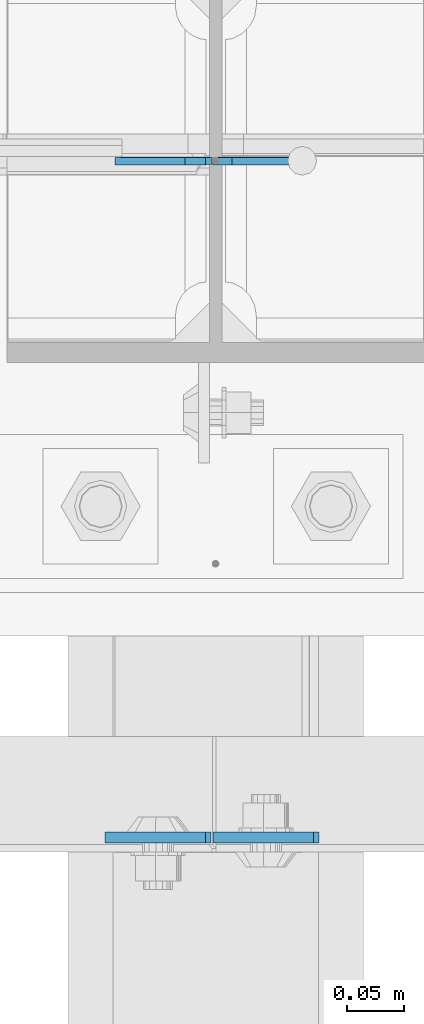
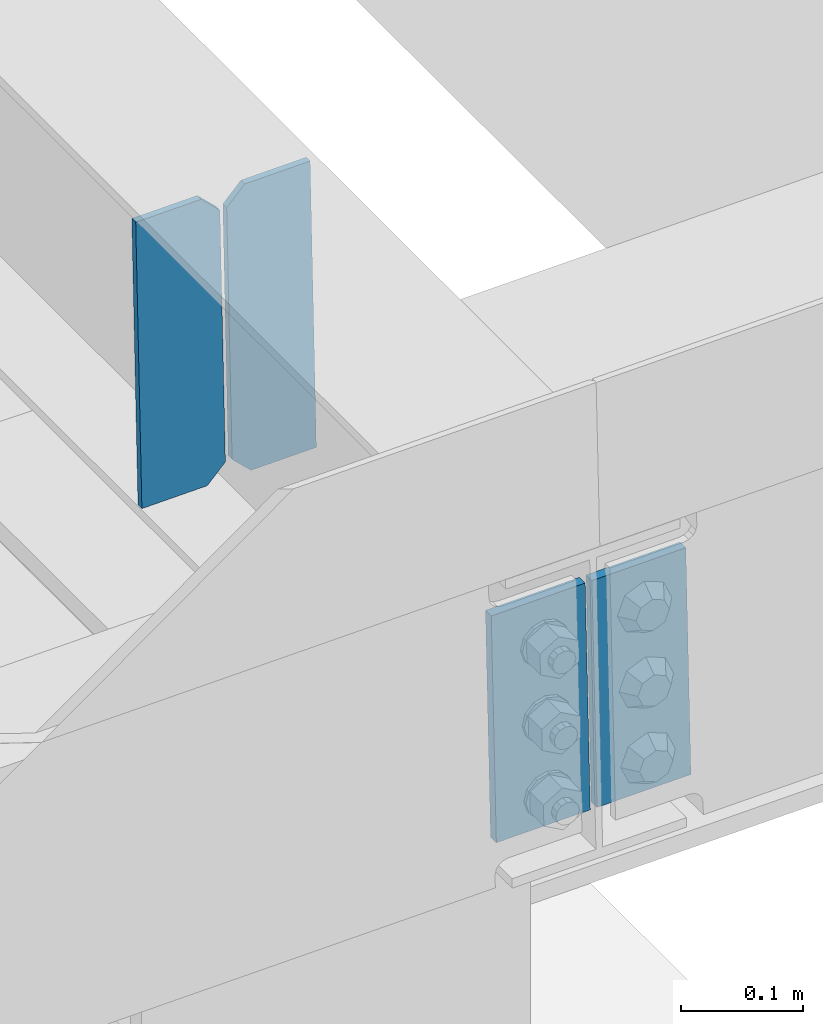
# One storey, part 3182 of 3843: 4 plates, 1 element without a shape of its own.
"""IFC2X3 building model written with IfcOpenShell, lengths in millimetres."""

import ifcopenshell
import ifcopenshell.guid

model = None  # the IFC model being written
_history = None  # IfcOwnerHistory: only IFC2X3 demands one
_inside = {}  # id of a spatial element -> (the spatial element, [elements in it])
_under = {}  # id of a project, library or spatial element -> (it, [spatial elements below it])
_declared = {}  # id of a project -> (the project, [libraries it declares])
_typed = {}  # id of a type object -> (the type object, [elements of that type])
_made_of = {}  # id of a material, layer set ... -> (it, [elements and type objects made of it])


def new_model(schema):
    """Start an empty IFC model of exactly this schema.

    Asked for "IFC4X3", IfcOpenShell would pick the latest addendum, in which some entities
    have other attributes; the version numbers below select the first issue.
    IFC2X3 requires an IfcOwnerHistory on every rooted entity: one is made here for all.
    """
    global model, _history
    if schema == "IFC4X3":
        model = ifcopenshell.file(schema_version=(4, 3, 0, 0))
    else:
        model = ifcopenshell.file(schema=schema)
    _inside.clear()
    _under.clear()
    _declared.clear()
    _typed.clear()
    _made_of.clear()
    _history = None
    if model.schema == "IFC2X3":
        org = make("IfcOrganization", Name="unknown")
        user = make(
            "IfcPersonAndOrganization",
            ThePerson=make("IfcPerson", FamilyName="unknown"),
            TheOrganization=org,
        )
        app = make(
            "IfcApplication",
            ApplicationDeveloper=org,
            Version="unknown",
            ApplicationFullName="unknown",
            ApplicationIdentifier="unknown",
        )
        _history = make(
            "IfcOwnerHistory",
            OwningUser=user,
            OwningApplication=app,
            ChangeAction="ADDED",
            CreationDate=0,
        )
    return model


def make(cls, **values):
    """One entity of the class cls with the attributes given. An attribute that is None is left unset."""
    return model.create_entity(
        cls, **{name: value for name, value in values.items() if value is not None}
    )


def rooted(cls, **values):
    """An entity with a GlobalId (a new one), such as an element, a storey or a relation."""
    return make(cls, GlobalId=ifcopenshell.guid.new(), OwnerHistory=_history, **values)


def si_unit(unit_type, name, prefix=None):
    """IfcSIUnit, for example si_unit("LENGTHUNIT", "METRE", prefix="MILLI")."""
    return make("IfcSIUnit", UnitType=unit_type, Prefix=prefix, Name=name)


def assignment(units):
    """IfcUnitAssignment: the units of a project."""
    return None if units is None else make("IfcUnitAssignment", Units=units)


def point(xyz):
    """IfcCartesianPoint."""
    return None if xyz is None else make("IfcCartesianPoint", Coordinates=xyz)


def direction(xyz):
    """IfcDirection."""
    return None if xyz is None else make("IfcDirection", DirectionRatios=xyz)


def frame(location, z_axis=None, x_axis=None):
    """IfcAxis2Placement3D, a coordinate frame: its origin and axes. An axis left out is left unset."""
    return make(
        "IfcAxis2Placement3D",
        Location=point(location),
        Axis=direction(z_axis),
        RefDirection=direction(x_axis),
    )


def origin_with_axes():
    """The frame at (0, 0, 0) with the z axis (0, 0, 1) and the x axis (1, 0, 0) written out."""
    return frame((0.0, 0.0, 0.0), z_axis=(0.0, 0.0, 1.0), x_axis=(1.0, 0.0, 0.0))


def place(relative_to, where):
    """IfcLocalPlacement: puts the frame where relative to a parent placement (None: the world)."""
    return make(
        "IfcLocalPlacement", PlacementRelTo=relative_to, RelativePlacement=where
    )


def context(
    kind, dimensions, precision=None, world=None, true_north=None, identifier=None
):
    """IfcGeometricRepresentationContext, for example the 3D "Model" context."""
    return make(
        "IfcGeometricRepresentationContext",
        ContextIdentifier=identifier,
        ContextType=kind,
        CoordinateSpaceDimension=dimensions,
        Precision=precision,
        WorldCoordinateSystem=world,
        TrueNorth=true_north,
    )


def subcontext(parent, identifier, kind, view, scale=None):
    """IfcGeometricRepresentationSubContext, for example "Body" below "Model"."""
    return make(
        "IfcGeometricRepresentationSubContext",
        ContextIdentifier=identifier,
        ContextType=kind,
        ParentContext=parent,
        TargetScale=scale,
        TargetView=view,
    )


def project(units=None, contexts=None):
    """IfcProject with its units and contexts."""
    return rooted(
        "IfcProject",
        Name="project",
        RepresentationContexts=contexts,
        UnitsInContext=assignment(units),
    )


def spatial(cls, under=None, at=None, **own):
    """A site, building, storey or space (cls), placed at a placement, below another one or the project."""
    s = rooted(cls, ObjectPlacement=at, **own)
    if under is not None:
        _under.setdefault(under.id(), (under, []))[1].append(s)
    return s


def faces_of(points, faces, orient=None, outer=None):
    """IfcFace entities. A face is a list of loops; a loop is a list of indices into points, from 0.

    orient and outer hold one flag for each loop. By default every Orientation is true, the
    first loop of a face is its IfcFaceOuterBound and the others are IfcFaceBound.
    """
    made = []
    for i, loops in enumerate(faces):
        bounds = []
        for j, loop in enumerate(loops):
            is_outer = j == 0 if outer is None else outer[i][j]
            bounds.append(
                make(
                    "IfcFaceOuterBound" if is_outer else "IfcFaceBound",
                    Bound=make("IfcPolyLoop", Polygon=[points[k] for k in loop]),
                    Orientation=True if orient is None else orient[i][j],
                )
            )
        made.append(make("IfcFace", Bounds=bounds))
    return made


def faceted_brep(points, faces, orient=None, outer=None, voids=None):
    """IfcFacetedBrep: a solid bounded by flat faces; with voids (closed shells), ...WithVoids."""
    shared = [point(p) for p in points]
    hull = make("IfcClosedShell", CfsFaces=faces_of(shared, faces, orient, outer))
    if voids is None:
        return make("IfcFacetedBrep", Outer=hull)
    return make(
        "IfcFacetedBrepWithVoids",
        Outer=hull,
        Voids=[
            make(cls, CfsFaces=faces_of(shared, fs, o, b)) for cls, fs, o, b in voids
        ],
    )


def shape(context_of_items, identifier, shape_type, items):
    """IfcShapeRepresentation: the items that make up one representation, for example the "Body"."""
    return make(
        "IfcShapeRepresentation",
        ContextOfItems=context_of_items,
        RepresentationIdentifier=identifier,
        RepresentationType=shape_type,
        Items=items,
    )


def material(Name=None, Category=None):
    """IfcMaterial."""
    return make("IfcMaterial", Name=Name, Category=Category)


def made_of(thing, what):
    """Note that an element or type object is made of a material, layer set ...; save() writes the relation."""
    if what is not None:
        _made_of.setdefault(what.id(), (what, []))[1].append(thing)
    return thing


def type_object(cls, material=None, **own):
    """A type object (cls), such as IfcWallType, which elements share."""
    return made_of(rooted(cls, **own), material)


def element(
    cls,
    number,
    at=None,
    inside=None,
    cuts=None,
    type_object=None,
    material=None,
    context=None,
    identifier="Body",
    shape_type=None,
    held_by="IfcProductDefinitionShape",
    body=None,
    shapes=None,
    **own,
):
    """One element of the class cls, such as IfcWall. Its Tag is "e" and its number.

    at: its placement. inside: the storey or other place that contains it. cuts: it is an
    opening in that element (IfcRelVoidsElement). A single representation is given by context,
    identifier, shape_type and body (its items); several are given by shapes. held_by: the class
    of the entity that holds the representations. save() writes the other relations.
    """
    e = rooted(cls, Tag="e%d" % number, ObjectPlacement=at, **own)
    if body is not None:
        shapes = [shape(context, identifier, shape_type, body)]
    if shapes is not None:
        e.Representation = make(held_by, Representations=shapes)
    if inside is not None:
        _inside.setdefault(inside.id(), (inside, []))[1].append(e)
    if cuts is not None:
        rooted(
            "IfcRelVoidsElement", RelatingBuildingElement=cuts, RelatedOpeningElement=e
        )
    if type_object is not None:
        _typed.setdefault(type_object.id(), (type_object, []))[1].append(e)
    return made_of(e, material)


def aggregate(whole, parts):
    """IfcRelAggregates: a whole, such as a stair, and the parts it consists of."""
    return rooted("IfcRelAggregates", RelatingObject=whole, RelatedObjects=parts)


def save(model, path):
    """Write the relations noted so far, then the file.

    IfcRelAggregates (storeys below a building ...), IfcRelContainedInSpatialStructure (elements
    in a storey), IfcRelDefinesByType, IfcRelAssociatesMaterial and IfcRelDeclares: one each for
    every whole, place, type object, material and project.
    """
    for whole, parts in _under.values():
        aggregate(whole, parts)
    for where, things in _inside.values():
        rooted(
            "IfcRelContainedInSpatialStructure",
            RelatedElements=things,
            RelatingStructure=where,
        )
    for kind, things in _typed.values():
        rooted("IfcRelDefinesByType", RelatedObjects=things, RelatingType=kind)
    for what, things in _made_of.values():
        rooted("IfcRelAssociatesMaterial", RelatedObjects=things, RelatingMaterial=what)
    for by, libraries in _declared.values():
        rooted("IfcRelDeclares", RelatingContext=by, RelatedDefinitions=libraries)
    model.write(path)


model = new_model("IFC2X3")

# Units and contexts
model_context = context("Model", 3, precision=1e-05, world=origin_with_axes())
body_context = subcontext(model_context, "Body", "Model", "MODEL_VIEW")
ifc_project = project(units=[si_unit("LENGTHUNIT", "METRE", prefix="MILLI"), si_unit("AREAUNIT", "SQUARE_METRE"), si_unit("VOLUMEUNIT", "CUBIC_METRE"), si_unit("MASSUNIT", "GRAM", prefix="KILO"), si_unit("TIMEUNIT", "SECOND"), si_unit("PLANEANGLEUNIT", "RADIAN"), si_unit("SOLIDANGLEUNIT", "STERADIAN"), si_unit("THERMODYNAMICTEMPERATUREUNIT", "DEGREE_CELSIUS"), si_unit("LUMINOUSINTENSITYUNIT", "LUMEN")], contexts=[model_context])

# Site, building, storey
site_placement = place(None, origin_with_axes())
site = spatial("IfcSite", under=ifc_project, at=site_placement, CompositionType="ELEMENT")
building_placement = place(site_placement, origin_with_axes())
building = spatial("IfcBuilding", under=site, at=building_placement, Name="Undefined", CompositionType="ELEMENT")
storey_placement = place(building_placement, origin_with_axes())
storey = spatial("IfcBuildingStorey", under=building, at=storey_placement, Name="Undefined", CompositionType="ELEMENT", Elevation=0.0)

# Assembly, plates
assembly_placement = place(storey_placement, origin_with_axes())
assembly = element("IfcElementAssembly", 1, at=assembly_placement, inside=storey, Name="BEAM", AssemblyPlace="NOTDEFINED", PredefinedType="RIGID_FRAME")
ifc_material = material(Name="STEEL/A572-50")
plate_type_1 = type_object("IfcPlateType", PredefinedType="NOTDEFINED")
plate_1_placement = place(assembly_placement, frame((62633.7992403779, 25019.0000000568, 46242.7865712119), z_axis=(0.999776270257024, 0.0, 0.0211520550054619), x_axis=(0.0211520550054438, 0.0, -0.999776270257025)))
plate_1 = element("IfcPlate", 2, at=plate_1_placement, type_object=plate_type_1, material=ifc_material, Name="PLATE", context=body_context, shape_type="Brep", body=[
    faceted_brep([(0.0, -4.76249999999709, 0.0), (0.0, -4.76249999999709, 88.9000015258789), (0.0, 4.76249999999709, 88.9000015258789), (0.0, 4.76249999999709, 0.0), (228.600006102781, -4.7625000004191, 88.9000015257589), (228.600006102781, 4.76249999954598, 88.9000015257443), (228.600006103079, -4.7625000004482, 7.27595761418343e-12), (228.600006103079, 4.76249999954598, -7.27595761418343e-12)], [[[0, 1, 2, 3]], [[1, 4, 5, 2]], [[4, 6, 7, 5]], [[6, 0, 3, 7]], [[5, 7, 3, 2]], [[6, 4, 1, 0]]]),
])
plate_2_placement = place(assembly_placement, frame((62627.4503745781, 25019.0000000848, 46242.6522471842), z_axis=(-0.999776270257024, 0.0, -0.0211520550054595), x_axis=(0.0211520550054438, 0.0, -0.999776270257025)))
plate_2 = element("IfcPlate", 3, at=plate_2_placement, type_object=plate_type_1, material=ifc_material, Name="PLATE", context=body_context, shape_type="Brep", body=[
    faceted_brep([(0.0, -4.76249999999709, 0.0), (0.0, -4.76249999999709, 88.9000015258789), (0.0, 4.76249999999709, 88.9000015258789), (0.0, 4.76249999999709, 0.0), (228.600006102781, -4.7625000004191, 88.9000015257589), (228.600006102781, 4.76249999954598, 88.9000015257443), (228.600006103079, -4.7625000004482, 7.27595761418343e-12), (228.600006103079, 4.76249999954598, -7.27595761418343e-12)], [[[0, 1, 2, 3]], [[1, 4, 5, 2]], [[4, 6, 7, 5]], [[6, 0, 3, 7]], [[5, 7, 3, 2]], [[6, 4, 1, 0]]]),
])
plate_type_2 = type_object("IfcPlateType", PredefinedType="NOTDEFINED")
plate_3_placement = place(assembly_placement, frame((62718.6964782604, 25615.9435611003, 45983.4538389283), z_axis=(-0.0211520984080489, -0.00142217399974833, 0.999775257822502), x_axis=(-0.999776269338764, 3.00890000219152e-05, -0.0211520770071379)))
plate_3 = element("IfcPlate", 4, at=plate_3_placement, type_object=plate_type_2, material=ifc_material, Name="STIFFENER", context=body_context, shape_type="Brep", body=[
    faceted_brep([(0.0, -3.17499999999927, 0.0), (6.83940015733242e-10, -3.17499999996653, 288.924999998613), (6.54836185276508e-10, 3.17500000001746, 288.924999998591), (0.0, 3.17499999999927, 0.0), (61.9125003828667, -3.17499999997744, 288.924999998599), (61.9125003828522, 3.17500000002838, 288.924999998584), (79.3750000013097, -3.17499999997744, 271.462500380039), (79.375000001266, 3.17500000002838, 271.462500380017), (79.375000000713, -3.17499999999927, 17.4624996185448), (79.3750000006694, 3.17500000000291, 17.462499618523), (61.9125003821828, -3.17499999999563, -1.45519152283669e-11), (61.9125003821682, 3.17500000000655, -2.91038304567337e-11)], [[[0, 1, 2, 3]], [[1, 4, 5, 2]], [[4, 6, 7, 5]], [[6, 8, 9, 7]], [[8, 10, 11, 9]], [[10, 0, 3, 11]], [[5, 7, 9, 11, 3, 2]], [[10, 8, 6, 4, 1, 0]]]),
])
plate_4_placement = place(assembly_placement, frame((62632.9906575708, 25615.9461404532, 45981.640577162), z_axis=(-0.0211520984080489, -0.00142217399974833, 0.999775257822502), x_axis=(-0.999776269338764, 3.00890000219152e-05, -0.0211520770071379)))
plate_4 = element("IfcPlate", 5, at=plate_4_placement, type_object=plate_type_2, material=ifc_material, Name="STIFFENER", context=body_context, shape_type="Brep", body=[
    faceted_brep([(5.82076609134674e-11, -3.17499999999927, 17.4624996185667), (6.25732354819775e-10, -3.17499999997744, 271.462500380054), (5.82076609134674e-10, 3.17500000002474, 271.462500380039), (0.0, 3.17500000000655, 17.4624996185521), (17.462499619156, -3.17499999997744, 288.924999998606), (17.4624996191269, 3.17500000002474, 288.924999998591), (79.3750000013242, -3.17500000025029, 288.924999998591), (79.3750000013097, 3.1749999997337, 288.92499999857), (79.3750000006548, -3.17500000026484, -2.18278728425503e-11), (79.3750000006403, 3.17499999969732, -2.91038304567337e-11), (17.4624996184866, -3.17500000000291, 7.27595761418343e-12), (17.462499618443, 3.17500000000291, -7.27595761418343e-12)], [[[0, 1, 2, 3]], [[1, 4, 5, 2]], [[4, 6, 7, 5]], [[6, 8, 9, 7]], [[8, 10, 11, 9]], [[10, 0, 3, 11]], [[5, 7, 9, 11, 3, 2]], [[10, 8, 6, 4, 1, 0]]]),
])
aggregate(assembly, [plate_1, plate_2, plate_3, plate_4])

save(model, "model.ifc")
